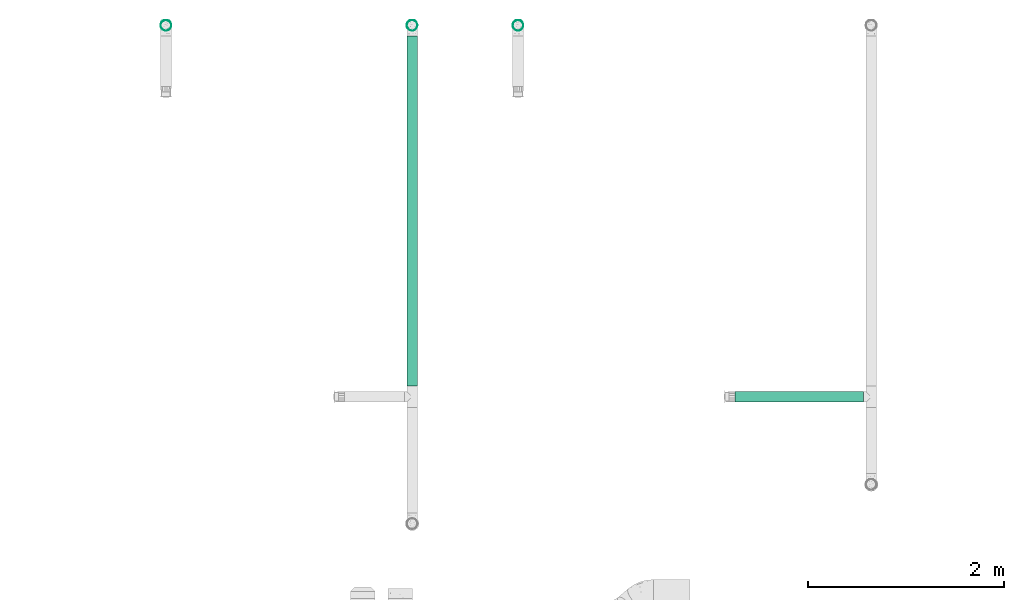
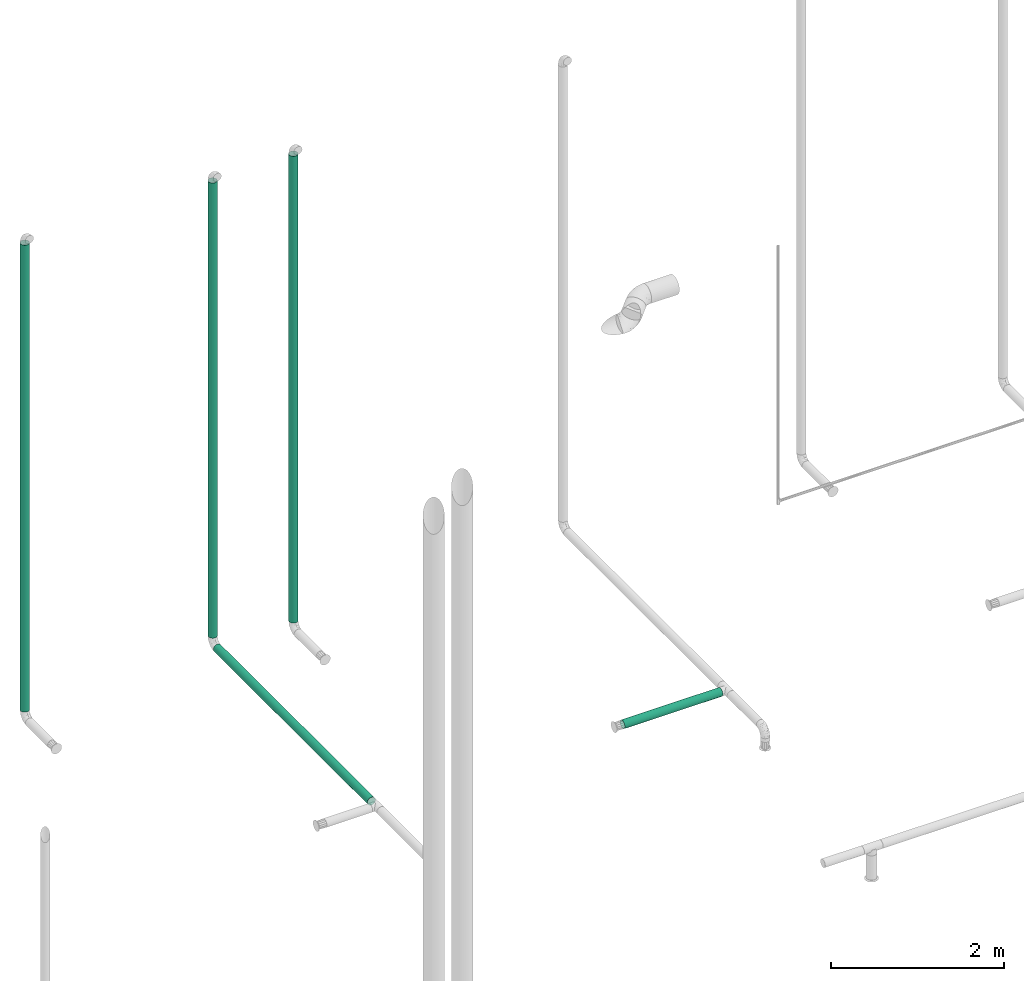
# One storey, part 6 of 123: 5 flow segments.
"""IFC2X3 building model written with IfcOpenShell, lengths in millimetres."""

from ifc_helpers import new_model, entity, si_unit, converted_unit, derived_unit, direction, frame, origin_with_axes, origin_2d_with_axis, place, context, subcontext, project, spatial, hollow_circle, extrude, source, transform, mapped, material, layer, layer_set, layer_usage, type_object, element, save


model = new_model("IFC2X3")

# Units and contexts
model_context = context("Model", 3, precision=1e-05, world=origin_with_axes(), true_north=direction((0.0, 1.0)))
body_context = subcontext(model_context, "Body", "Model", "MODEL_VIEW")
ifc_project = project(units=[si_unit("AREAUNIT", "SQUARE_METRE"), si_unit("VOLUMEUNIT", "CUBIC_METRE", prefix="DECI"), si_unit("TIMEUNIT", "SECOND"), si_unit("THERMODYNAMICTEMPERATUREUNIT", "DEGREE_CELSIUS"), si_unit("PRESSUREUNIT", "PASCAL"), si_unit("MASSUNIT", "GRAM", prefix="KILO"), si_unit("LENGTHUNIT", "METRE", prefix="MILLI"), si_unit("POWERUNIT", "WATT"), si_unit("ELECTRICCURRENTUNIT", "AMPERE"), si_unit("ELECTRICVOLTAGEUNIT", "VOLT"), derived_unit("VOLUMETRICFLOWRATEUNIT", [(si_unit("VOLUMEUNIT", "CUBIC_METRE", prefix="DECI"), 1), (si_unit("TIMEUNIT", "SECOND"), -1)]), derived_unit("LINEARVELOCITYUNIT", [(si_unit("LENGTHUNIT", "METRE"), 1), (si_unit("TIMEUNIT", "SECOND"), -1)]), derived_unit("MASSDENSITYUNIT", [(si_unit("MASSUNIT", "GRAM", prefix="KILO"), 1), (si_unit("VOLUMEUNIT", "CUBIC_METRE"), -1)]), converted_unit("PLANEANGLEUNIT", "DEGREE", entity("IfcRatioMeasure", 0.01745), si_unit("PLANEANGLEUNIT", "RADIAN"), dimensions=[0, 0, 0, 0, 0, 0, 0])], contexts=[model_context])

# Site, building, storey
site_placement = place(None, origin_with_axes())
site = spatial("IfcSite", under=ifc_project, at=site_placement, CompositionType="ELEMENT")
building_placement = place(site_placement, origin_with_axes())
building = spatial("IfcBuilding", under=site, at=building_placement, Name="mc-building", CompositionType="ELEMENT")
storey_placement = place(building_placement, origin_with_axes())
storey = spatial("IfcBuildingStorey", under=building, at=storey_placement, Name="1. Korrus", CompositionType="ELEMENT", Elevation=0.0)

# Flow segments
ifc_material = material(Name="FZ1")
ifc_layer = layer(ifc_material, 0.0)
ifc_layer_set = layer_set([ifc_layer], Name="FZ1")
ifc_layer_usage = layer_usage(ifc_layer_set, "AXIS1", "POSITIVE", 0.0)
duct_segment_type = type_object("IfcDuctSegmentType", PredefinedType="RIGIDSEGMENT")
shared_shape_1 = source(origin_with_axes(), body_context, "Body", "SweptSolid", [
    extrude(hollow_circle(Radius=55.0, WallThickness=2.0, at=origin_2d_with_axis()), frame((0.0, 0.0, 0.0), z_axis=(1.0, 0.0, 0.0), x_axis=(0.0, 1.0, 0.0)), (0.0, 0.0, 1.0), 3565.9),
])
flow_segment_1_placement = place(storey_placement, frame((7686.9773, 13553.57591, 2465.0), z_axis=(0.0, 0.0, 1.0), x_axis=(0.0, -1.0, 0.0)))
element("IfcFlowSegment", 1, at=flow_segment_1_placement, inside=storey, type_object=duct_segment_type, material=ifc_layer_usage, context=body_context, shape_type="MappedRepresentation", body=[
    mapped(shared_shape_1, transform((0.0, 0.0, 0.0), scale=1.0)),
])
shared_shape_2 = source(origin_with_axes(), body_context, "Body", "SweptSolid", [
    extrude(hollow_circle(Radius=55.0, WallThickness=2.0, at=origin_2d_with_axis()), frame((0.0, 0.0, 0.0), z_axis=(1.0, 0.0, 0.0), x_axis=(0.0, 1.0, 0.0)), (0.0, 0.0, 1.0), 6595.0),
])
for number, where, z_axis, x_axis in (
    (2, (5177.14677, 13663.57591, 2410.0), (0.0, -1.0, 0.0), (0.0, 0.0, 1.0)),
    (3, (8766.57414, 13663.57591, 2410.0), (0.0, -1.0, 0.0), (0.0, 0.0, 1.0)),
):
    element("IfcFlowSegment", number, at=place(storey_placement, frame(where, z_axis=z_axis, x_axis=x_axis)), inside=storey, type_object=duct_segment_type, material=ifc_layer_usage, context=body_context, shape_type="MappedRepresentation", body=[
        mapped(shared_shape_2, transform((0.0, 0.0, 0.0), scale=1.0)),
    ])
shared_shape_3 = source(origin_with_axes(), body_context, "Body", "SweptSolid", [
    extrude(hollow_circle(Radius=55.0, WallThickness=2.0, at=origin_2d_with_axis()), frame((0.0, 0.0, 0.0), z_axis=(1.0, 0.0, 0.0), x_axis=(0.0, 1.0, 0.0)), (0.0, 0.0, 1.0), 6430.0),
])
flow_segment_2_placement = place(storey_placement, frame((7686.9773, 13663.57591, 2575.0), z_axis=(0.0, -1.0, 0.0), x_axis=(0.0, 0.0, 1.0)))
element("IfcFlowSegment", 4, at=flow_segment_2_placement, inside=storey, type_object=duct_segment_type, material=ifc_layer_usage, context=body_context, shape_type="MappedRepresentation", body=[
    mapped(shared_shape_3, transform((0.0, 0.0, 0.0), scale=1.0)),
])
shared_shape_4 = source(origin_with_axes(), body_context, "Body", "SweptSolid", [
    extrude(hollow_circle(Radius=55.0, WallThickness=2.0, at=origin_2d_with_axis()), frame((0.0, 0.0, 0.0), z_axis=(1.0, 0.0, 0.0), x_axis=(0.0, 1.0, 0.0)), (0.0, 0.0, 1.0), 1309.2),
])
flow_segment_3_placement = place(storey_placement, frame((12286.76802, 9877.62755, 2465.0), z_axis=(0.0, 0.0, 1.0), x_axis=(-1.0, 0.0, 0.0)))
element("IfcFlowSegment", 5, at=flow_segment_3_placement, inside=storey, type_object=duct_segment_type, material=ifc_layer_usage, context=body_context, shape_type="MappedRepresentation", body=[
    mapped(shared_shape_4, transform((0.0, 0.0, 0.0), scale=1.0)),
])

save(model, "model.ifc")
